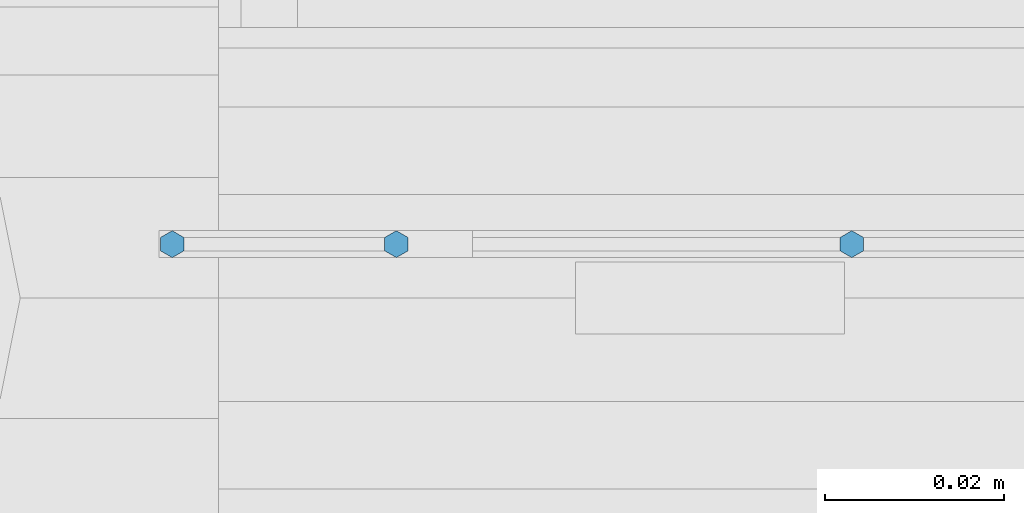
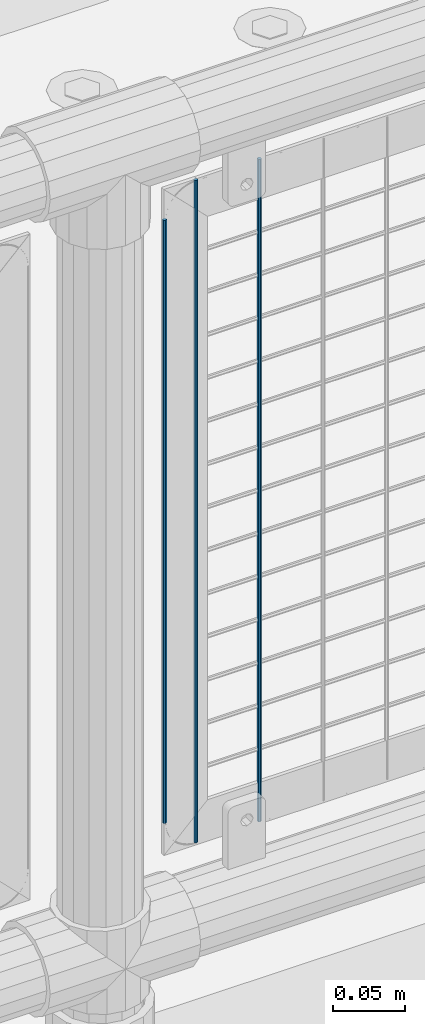
# One storey, part 107 of 270: 3 columns.
"""IFC2X3 building model written with IfcOpenShell, lengths in millimetres."""

import ifcopenshell
import ifcopenshell.guid

model = None  # the IFC model being written
_history = None  # IfcOwnerHistory: only IFC2X3 demands one
_inside = {}  # id of a spatial element -> (the spatial element, [elements in it])
_under = {}  # id of a project, library or spatial element -> (it, [spatial elements below it])
_declared = {}  # id of a project -> (the project, [libraries it declares])
_typed = {}  # id of a type object -> (the type object, [elements of that type])
_made_of = {}  # id of a material, layer set ... -> (it, [elements and type objects made of it])


def new_model(schema):
    """Start an empty IFC model of exactly this schema.

    Asked for "IFC4X3", IfcOpenShell would pick the latest addendum, in which some entities
    have other attributes; the version numbers below select the first issue.
    IFC2X3 requires an IfcOwnerHistory on every rooted entity: one is made here for all.
    """
    global model, _history
    if schema == "IFC4X3":
        model = ifcopenshell.file(schema_version=(4, 3, 0, 0))
    else:
        model = ifcopenshell.file(schema=schema)
    _inside.clear()
    _under.clear()
    _declared.clear()
    _typed.clear()
    _made_of.clear()
    _history = None
    if model.schema == "IFC2X3":
        org = make("IfcOrganization", Name="unknown")
        user = make(
            "IfcPersonAndOrganization",
            ThePerson=make("IfcPerson", FamilyName="unknown"),
            TheOrganization=org,
        )
        app = make(
            "IfcApplication",
            ApplicationDeveloper=org,
            Version="unknown",
            ApplicationFullName="unknown",
            ApplicationIdentifier="unknown",
        )
        _history = make(
            "IfcOwnerHistory",
            OwningUser=user,
            OwningApplication=app,
            ChangeAction="ADDED",
            CreationDate=0,
        )
    return model


def make(cls, **values):
    """One entity of the class cls with the attributes given. An attribute that is None is left unset."""
    return model.create_entity(
        cls, **{name: value for name, value in values.items() if value is not None}
    )


def rooted(cls, **values):
    """An entity with a GlobalId (a new one), such as an element, a storey or a relation."""
    return make(cls, GlobalId=ifcopenshell.guid.new(), OwnerHistory=_history, **values)


def si_unit(unit_type, name, prefix=None):
    """IfcSIUnit, for example si_unit("LENGTHUNIT", "METRE", prefix="MILLI")."""
    return make("IfcSIUnit", UnitType=unit_type, Prefix=prefix, Name=name)


def assignment(units):
    """IfcUnitAssignment: the units of a project."""
    return None if units is None else make("IfcUnitAssignment", Units=units)


def point(xyz):
    """IfcCartesianPoint."""
    return None if xyz is None else make("IfcCartesianPoint", Coordinates=xyz)


def direction(xyz):
    """IfcDirection."""
    return None if xyz is None else make("IfcDirection", DirectionRatios=xyz)


def frame(location, z_axis=None, x_axis=None):
    """IfcAxis2Placement3D, a coordinate frame: its origin and axes. An axis left out is left unset."""
    return make(
        "IfcAxis2Placement3D",
        Location=point(location),
        Axis=direction(z_axis),
        RefDirection=direction(x_axis),
    )


def origin_with_axes():
    """The frame at (0, 0, 0) with the z axis (0, 0, 1) and the x axis (1, 0, 0) written out."""
    return frame((0.0, 0.0, 0.0), z_axis=(0.0, 0.0, 1.0), x_axis=(1.0, 0.0, 0.0))


def place(relative_to, where):
    """IfcLocalPlacement: puts the frame where relative to a parent placement (None: the world)."""
    return make(
        "IfcLocalPlacement", PlacementRelTo=relative_to, RelativePlacement=where
    )


def context(
    kind, dimensions, precision=None, world=None, true_north=None, identifier=None
):
    """IfcGeometricRepresentationContext, for example the 3D "Model" context."""
    return make(
        "IfcGeometricRepresentationContext",
        ContextIdentifier=identifier,
        ContextType=kind,
        CoordinateSpaceDimension=dimensions,
        Precision=precision,
        WorldCoordinateSystem=world,
        TrueNorth=true_north,
    )


def subcontext(parent, identifier, kind, view, scale=None):
    """IfcGeometricRepresentationSubContext, for example "Body" below "Model"."""
    return make(
        "IfcGeometricRepresentationSubContext",
        ContextIdentifier=identifier,
        ContextType=kind,
        ParentContext=parent,
        TargetScale=scale,
        TargetView=view,
    )


def project(units=None, contexts=None):
    """IfcProject with its units and contexts."""
    return rooted(
        "IfcProject",
        Name="project",
        RepresentationContexts=contexts,
        UnitsInContext=assignment(units),
    )


def spatial(cls, under=None, at=None, **own):
    """A site, building, storey or space (cls), placed at a placement, below another one or the project."""
    s = rooted(cls, ObjectPlacement=at, **own)
    if under is not None:
        _under.setdefault(under.id(), (under, []))[1].append(s)
    return s


def faces_of(points, faces, orient=None, outer=None):
    """IfcFace entities. A face is a list of loops; a loop is a list of indices into points, from 0.

    orient and outer hold one flag for each loop. By default every Orientation is true, the
    first loop of a face is its IfcFaceOuterBound and the others are IfcFaceBound.
    """
    made = []
    for i, loops in enumerate(faces):
        bounds = []
        for j, loop in enumerate(loops):
            is_outer = j == 0 if outer is None else outer[i][j]
            bounds.append(
                make(
                    "IfcFaceOuterBound" if is_outer else "IfcFaceBound",
                    Bound=make("IfcPolyLoop", Polygon=[points[k] for k in loop]),
                    Orientation=True if orient is None else orient[i][j],
                )
            )
        made.append(make("IfcFace", Bounds=bounds))
    return made


def faceted_brep(points, faces, orient=None, outer=None, voids=None):
    """IfcFacetedBrep: a solid bounded by flat faces; with voids (closed shells), ...WithVoids."""
    shared = [point(p) for p in points]
    hull = make("IfcClosedShell", CfsFaces=faces_of(shared, faces, orient, outer))
    if voids is None:
        return make("IfcFacetedBrep", Outer=hull)
    return make(
        "IfcFacetedBrepWithVoids",
        Outer=hull,
        Voids=[
            make(cls, CfsFaces=faces_of(shared, fs, o, b)) for cls, fs, o, b in voids
        ],
    )


def shape(context_of_items, identifier, shape_type, items):
    """IfcShapeRepresentation: the items that make up one representation, for example the "Body"."""
    return make(
        "IfcShapeRepresentation",
        ContextOfItems=context_of_items,
        RepresentationIdentifier=identifier,
        RepresentationType=shape_type,
        Items=items,
    )


def material(Name=None, Category=None):
    """IfcMaterial."""
    return make("IfcMaterial", Name=Name, Category=Category)


def made_of(thing, what):
    """Note that an element or type object is made of a material, layer set ...; save() writes the relation."""
    if what is not None:
        _made_of.setdefault(what.id(), (what, []))[1].append(thing)
    return thing


def type_object(cls, material=None, **own):
    """A type object (cls), such as IfcWallType, which elements share."""
    return made_of(rooted(cls, **own), material)


def element(
    cls,
    number,
    at=None,
    inside=None,
    cuts=None,
    type_object=None,
    material=None,
    context=None,
    identifier="Body",
    shape_type=None,
    held_by="IfcProductDefinitionShape",
    body=None,
    shapes=None,
    **own,
):
    """One element of the class cls, such as IfcWall. Its Tag is "e" and its number.

    at: its placement. inside: the storey or other place that contains it. cuts: it is an
    opening in that element (IfcRelVoidsElement). A single representation is given by context,
    identifier, shape_type and body (its items); several are given by shapes. held_by: the class
    of the entity that holds the representations. save() writes the other relations.
    """
    e = rooted(cls, Tag="e%d" % number, ObjectPlacement=at, **own)
    if body is not None:
        shapes = [shape(context, identifier, shape_type, body)]
    if shapes is not None:
        e.Representation = make(held_by, Representations=shapes)
    if inside is not None:
        _inside.setdefault(inside.id(), (inside, []))[1].append(e)
    if cuts is not None:
        rooted(
            "IfcRelVoidsElement", RelatingBuildingElement=cuts, RelatedOpeningElement=e
        )
    if type_object is not None:
        _typed.setdefault(type_object.id(), (type_object, []))[1].append(e)
    return made_of(e, material)


def aggregate(whole, parts):
    """IfcRelAggregates: a whole, such as a stair, and the parts it consists of."""
    return rooted("IfcRelAggregates", RelatingObject=whole, RelatedObjects=parts)


def save(model, path):
    """Write the relations noted so far, then the file.

    IfcRelAggregates (storeys below a building ...), IfcRelContainedInSpatialStructure (elements
    in a storey), IfcRelDefinesByType, IfcRelAssociatesMaterial and IfcRelDeclares: one each for
    every whole, place, type object, material and project.
    """
    for whole, parts in _under.values():
        aggregate(whole, parts)
    for where, things in _inside.values():
        rooted(
            "IfcRelContainedInSpatialStructure",
            RelatedElements=things,
            RelatingStructure=where,
        )
    for kind, things in _typed.values():
        rooted("IfcRelDefinesByType", RelatedObjects=things, RelatingType=kind)
    for what, things in _made_of.values():
        rooted("IfcRelAssociatesMaterial", RelatedObjects=things, RelatingMaterial=what)
    for by, libraries in _declared.values():
        rooted("IfcRelDeclares", RelatingContext=by, RelatedDefinitions=libraries)
    model.write(path)


model = new_model("IFC2X3")

# Units and contexts
model_context = context("Model", 3, precision=1e-05, world=origin_with_axes())
body_context = subcontext(model_context, "Body", "Model", "MODEL_VIEW")
ifc_project = project(units=[si_unit("LENGTHUNIT", "METRE", prefix="MILLI"), si_unit("AREAUNIT", "SQUARE_METRE"), si_unit("VOLUMEUNIT", "CUBIC_METRE"), si_unit("MASSUNIT", "GRAM", prefix="KILO"), si_unit("TIMEUNIT", "SECOND"), si_unit("PLANEANGLEUNIT", "RADIAN"), si_unit("SOLIDANGLEUNIT", "STERADIAN"), si_unit("THERMODYNAMICTEMPERATUREUNIT", "DEGREE_CELSIUS"), si_unit("LUMINOUSINTENSITYUNIT", "LUMEN")], contexts=[model_context])

# Site, building, storey
site_placement = place(None, origin_with_axes())
site = spatial("IfcSite", under=ifc_project, at=site_placement, CompositionType="ELEMENT")
building_placement = place(site_placement, origin_with_axes())
building = spatial("IfcBuilding", under=site, at=building_placement, Name="Standard", CompositionType="ELEMENT")
storey_placement = place(building_placement, origin_with_axes())
storey = spatial("IfcBuildingStorey", under=building, at=storey_placement, Name="Undefined", CompositionType="ELEMENT", Elevation=0.0)

# Columns
ifc_material = material(Name="Misc_Undefined")
column_type = type_object("IfcColumnType", Name="D3", PredefinedType="NOTDEFINED")
column_1_placement = place(storey_placement, frame((17081.793, -16329.5, 353.02), z_axis=(-1.0, 0.0, 0.0), x_axis=(0.0, 0.0, 1.0)))
element("IfcColumn", 1, at=column_1_placement, inside=storey, type_object=column_type, material=ifc_material, ObjectType="D3", context=body_context, shape_type="Brep", body=[
    faceted_brep([(0.0, -1.5, 0.0), (0.0, -0.75, -1.29903810567669), (560.0, -0.75, -1.29903810567703), (560.0, -1.5, 0.0), (0.0, 0.75, -1.29903810567669), (560.0, 0.75, -1.29903810567703), (0.0, 1.5, 0.0), (560.0, 1.5, 0.0), (0.0, 0.75, 1.29903810567669), (560.0, 0.75, 1.29903810567703), (0.0, -0.75, 1.29903810567669), (560.0, -0.75, 1.29903810567703)], [[[0, 1, 2, 3]], [[1, 4, 5, 2]], [[4, 6, 7, 5]], [[6, 8, 9, 7]], [[8, 10, 11, 9]], [[10, 0, 3, 11]], [[5, 7, 9, 11, 3, 2]], [[10, 8, 6, 4, 1, 0]]]),
])
column_2_placement = place(storey_placement, frame((17006.0, -16329.5, 378.02), z_axis=(-1.0, 0.0, 0.0), x_axis=(0.0, 0.0, 1.0)))
element("IfcColumn", 2, at=column_2_placement, inside=storey, type_object=column_type, material=ifc_material, ObjectType="D3", context=body_context, shape_type="Brep", body=[
    faceted_brep([(0.0, -1.5, 0.0), (0.0, -0.75, -1.29903810567669), (510.0, -0.75, -1.29903810567703), (510.0, -1.5, 0.0), (0.0, 0.75, -1.29903810567669), (510.0, 0.75, -1.29903810567703), (0.0, 1.5, 0.0), (510.0, 1.5, 0.0), (0.0, 0.75, 1.29903810567669), (510.0, 0.75, 1.29903810567703), (0.0, -0.75, 1.29903810567669), (510.0, -0.75, 1.29903810567703)], [[[0, 1, 2, 3]], [[1, 4, 5, 2]], [[4, 6, 7, 5]], [[6, 8, 9, 7]], [[8, 10, 11, 9]], [[10, 0, 3, 11]], [[5, 7, 9, 11, 3, 2]], [[10, 8, 6, 4, 1, 0]]]),
])
column_3_placement = place(storey_placement, frame((17031.0, -16329.5, 353.02), z_axis=(-1.0, 0.0, 0.0), x_axis=(0.0, 0.0, 1.0)))
element("IfcColumn", 3, at=column_3_placement, inside=storey, type_object=column_type, material=ifc_material, ObjectType="D3", context=body_context, shape_type="Brep", body=[
    faceted_brep([(0.0, -1.5, 0.0), (0.0, -0.75, -1.29903810567669), (560.0, -0.75, -1.29903810567703), (560.0, -1.5, 0.0), (0.0, 0.75, -1.29903810567669), (560.0, 0.75, -1.29903810567703), (0.0, 1.5, 0.0), (560.0, 1.5, 0.0), (0.0, 0.75, 1.29903810567669), (560.0, 0.75, 1.29903810567703), (0.0, -0.75, 1.29903810567669), (560.0, -0.75, 1.29903810567703)], [[[0, 1, 2, 3]], [[1, 4, 5, 2]], [[4, 6, 7, 5]], [[6, 8, 9, 7]], [[8, 10, 11, 9]], [[10, 0, 3, 11]], [[5, 7, 9, 11, 3, 2]], [[10, 8, 6, 4, 1, 0]]]),
])

save(model, "model.ifc")
